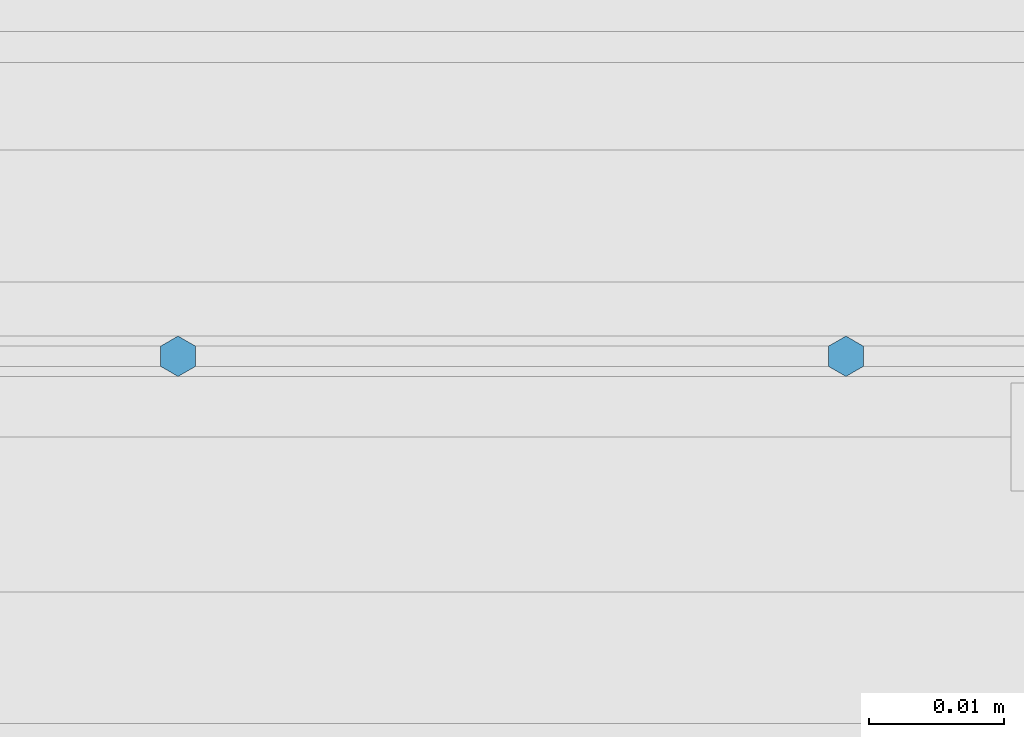
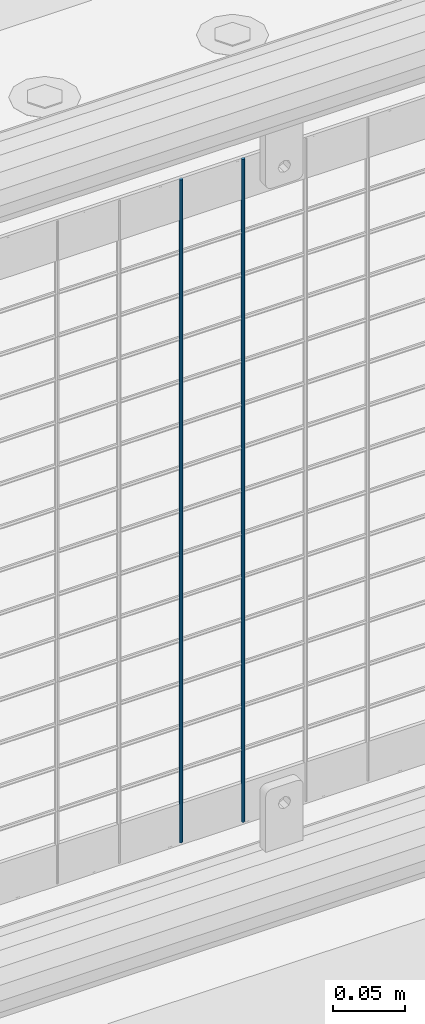
# One storey, part 56 of 208: 2 columns.
"""IFC2X3 building model written with IfcOpenShell, lengths in millimetres."""

from ifc_helpers import new_model, si_unit, frame, origin_with_axes, place, context, subcontext, project, spatial, faceted_brep, material, type_object, element, save


model = new_model("IFC2X3")

# Units and contexts
model_context = context("Model", 3, precision=1e-05, world=origin_with_axes())
body_context = subcontext(model_context, "Body", "Model", "MODEL_VIEW")
ifc_project = project(units=[si_unit("LENGTHUNIT", "METRE", prefix="MILLI"), si_unit("AREAUNIT", "SQUARE_METRE"), si_unit("VOLUMEUNIT", "CUBIC_METRE"), si_unit("MASSUNIT", "GRAM", prefix="KILO"), si_unit("TIMEUNIT", "SECOND"), si_unit("PLANEANGLEUNIT", "RADIAN"), si_unit("SOLIDANGLEUNIT", "STERADIAN"), si_unit("THERMODYNAMICTEMPERATUREUNIT", "DEGREE_CELSIUS"), si_unit("LUMINOUSINTENSITYUNIT", "LUMEN")], contexts=[model_context])

# Site, building, storey
site_placement = place(None, origin_with_axes())
site = spatial("IfcSite", under=ifc_project, at=site_placement, CompositionType="ELEMENT")
building_placement = place(site_placement, origin_with_axes())
building = spatial("IfcBuilding", under=site, at=building_placement, Name="Standard", CompositionType="ELEMENT")
storey_placement = place(building_placement, origin_with_axes())
storey = spatial("IfcBuildingStorey", under=building, at=storey_placement, Name="Undefined", CompositionType="ELEMENT", Elevation=0.0)

# Columns
ifc_material = material(Name="Misc_Undefined")
column_type = type_object("IfcColumnType", Name="D3", PredefinedType="NOTDEFINED")
for number, where, z_axis, x_axis in (
    (1, (-41401.415, 4670.5, 353.02), (-1.0, 0.0, 0.0), (0.0, 0.0, 1.0)),
    (2, (-41451.07, 4670.5, 353.02), (-1.0, 0.0, 0.0), (0.0, 0.0, 1.0)),
):
    element("IfcColumn", number, at=place(storey_placement, frame(where, z_axis=z_axis, x_axis=x_axis)), inside=storey, type_object=column_type, material=ifc_material, ObjectType="D3", context=body_context, shape_type="Brep", body=[
        faceted_brep([(0.0, -1.49999999999909, 3.63797880709171e-12), (-7.27595761418343e-12, -0.749999999999091, -1.29903810567669), (560.0, -0.75, -1.29903810567703), (560.0, -1.5, 0.0), (-3.63797880709171e-12, 0.750000000000909, -1.29903810567669), (560.0, 0.75, -1.29903810567703), (0.0, 1.50000000000182, 3.63797880709171e-12), (560.0, 1.5, 0.0), (-3.63797880709171e-12, 0.750000000000909, 1.29903810567669), (560.0, 0.75, 1.29903810567703), (-7.27595761418343e-12, -0.749999999999091, 1.29903810567669), (560.0, -0.75, 1.29903810567703)], [[[0, 1, 2, 3]], [[1, 4, 5, 2]], [[4, 6, 7, 5]], [[6, 8, 9, 7]], [[8, 10, 11, 9]], [[10, 0, 3, 11]], [[5, 7, 9, 11, 3, 2]], [[10, 8, 6, 4, 1, 0]]]),
    ])

save(model, "model.ifc")
